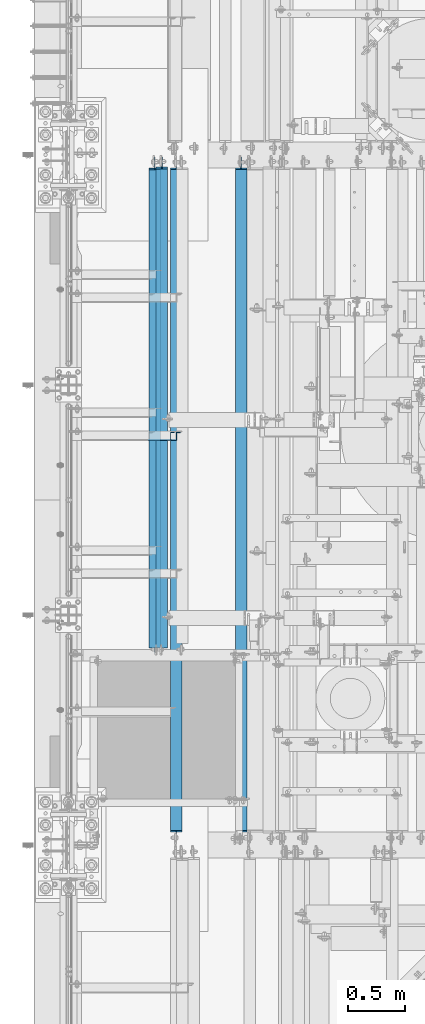
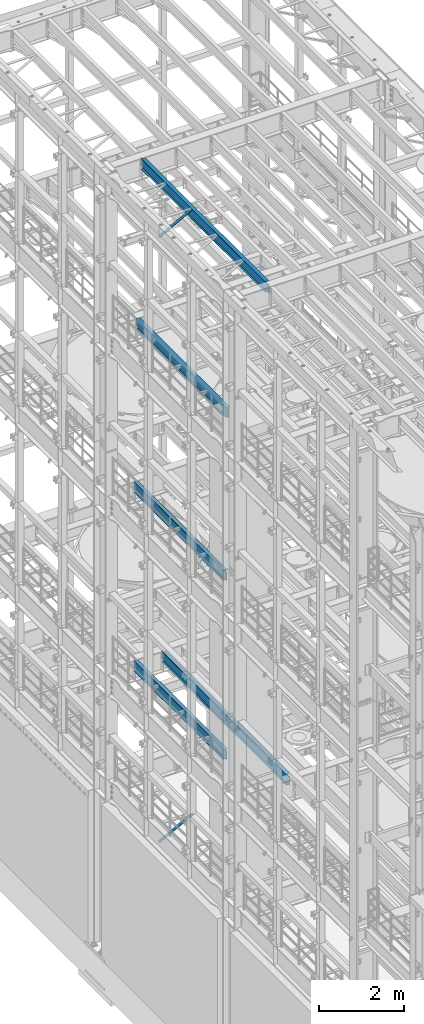
# One storey, part 1023 of 1876: 5 beams, 2 members, 7 elements without a shape of their own.
"""IFC2X3 building model written with IfcOpenShell, lengths in millimetres."""

from ifc_helpers import new_model, si_unit, frame, origin_with_axes, place, context, subcontext, project, spatial, faceted_brep, material, type_object, element, aggregate, save


model = new_model("IFC2X3")

# Units and contexts
model_context = context("Model", 3, precision=1e-05, world=origin_with_axes())
body_context = subcontext(model_context, "Body", "Model", "MODEL_VIEW")
ifc_project = project(units=[si_unit("LENGTHUNIT", "METRE", prefix="MILLI"), si_unit("AREAUNIT", "SQUARE_METRE"), si_unit("VOLUMEUNIT", "CUBIC_METRE"), si_unit("MASSUNIT", "GRAM", prefix="KILO"), si_unit("TIMEUNIT", "SECOND"), si_unit("PLANEANGLEUNIT", "RADIAN"), si_unit("SOLIDANGLEUNIT", "STERADIAN"), si_unit("THERMODYNAMICTEMPERATUREUNIT", "DEGREE_CELSIUS"), si_unit("LUMINOUSINTENSITYUNIT", "LUMEN")], contexts=[model_context])

# Site, building, storey
site_placement = place(None, origin_with_axes())
site = spatial("IfcSite", under=ifc_project, at=site_placement, CompositionType="ELEMENT")
building_placement = place(site_placement, origin_with_axes())
building = spatial("IfcBuilding", under=site, at=building_placement, Name="Undefined", CompositionType="ELEMENT")
storey_placement = place(building_placement, origin_with_axes())
storey = spatial("IfcBuildingStorey", under=building, at=storey_placement, Name="Undefined", CompositionType="ELEMENT", Elevation=0.0)

# Assembly, member
assembly_1_placement = place(storey_placement, origin_with_axes())
assembly_1 = element("IfcElementAssembly", 1, at=assembly_1_placement, inside=storey, AssemblyPlace="NOTDEFINED", PredefinedType="RIGID_FRAME")
ifc_material_1 = material(Name="STEEL/A36")
member_type = type_object("IfcMemberType", Name="L3X3X3/8", PredefinedType="NOTDEFINED")
member_1_placement = place(assembly_1_placement, frame((18.2754879686868, 5133.975, 22001.0692535961), z_axis=(0.0, -1.0, 0.0), x_axis=(0.877448093107104, 0.0, 0.479671600058526)))
member_1 = element("IfcMember", 2, at=member_1_placement, type_object=member_type, material=ifc_material_1, ObjectType="L3X3X3/8", context=body_context, shape_type="Brep", body=[
    faceted_brep([(22.6152978728696, 38.0999999999985, -38.0999999999999), (22.6152978728696, 38.0999999999985, 38.0999999999999), (1025.78606203808, 38.1000000013628, 38.0999999999999), (1025.78606203808, 38.1000000013628, -38.0999999999999), (22.6152978728605, 28.5750000000044, 38.0999999999999), (1025.78606203807, 28.5750000013722, 38.0999999999999), (22.6152978728605, 28.5750000000044, -28.5749999999998), (1025.78606203807, 28.5750000013722, -28.5749999999998), (22.6152978728023, -38.0999999999367, -28.5749999999998), (1025.78606203801, -38.0999999985652, -28.5749999999998), (22.6152978728023, -38.0999999999367, -38.0999999999999), (1025.78606203801, -38.0999999985652, -38.0999999999999)], [[[0, 1, 2, 3]], [[1, 4, 5, 2]], [[4, 6, 7, 5]], [[6, 8, 9, 7]], [[8, 10, 11, 9]], [[10, 0, 3, 11]], [[5, 7, 9, 11, 3, 2]], [[10, 8, 6, 4, 1, 0]]]),
])
aggregate(assembly_1, [member_1])

assembly_2_placement = place(storey_placement, origin_with_axes())
assembly_2 = element("IfcElementAssembly", 3, at=assembly_2_placement, inside=storey, AssemblyPlace="NOTDEFINED", PredefinedType="RIGID_FRAME")
member_2_placement = place(assembly_2_placement, frame((17.6081923269563, 5133.975, 4576.47197854001), z_axis=(0.0, -1.0, 0.0), x_axis=(0.885896503105539, 0.0, 0.463882944055263)))
member_2 = element("IfcMember", 4, at=member_2_placement, type_object=member_type, material=ifc_material_1, ObjectType="L3X3X3/8", context=body_context, shape_type="Brep", body=[
    faceted_brep([(22.4738417769599, 38.1000000000004, -38.0999999999999), (22.4738417769599, 38.1000000000004, 38.0999999999999), (1074.30197854536, 38.1000000002496, 38.0999999999999), (1074.30197854536, 38.1000000002496, -38.0999999999999), (22.4738417769613, 28.5749999999998, 38.0999999999999), (1074.30197854535, 28.5750000002463, 38.0999999999999), (22.4738417769613, 28.5749999999998, -28.5749999999998), (1074.30197854535, 28.5750000002463, -28.5749999999998), (22.4738417769699, -38.100000000004, -28.5749999999998), (1074.30197854533, -38.099999999773, -28.5749999999998), (22.4738417769699, -38.100000000004, -38.0999999999999), (1074.30197854533, -38.099999999773, -38.0999999999999)], [[[0, 1, 2, 3]], [[1, 4, 5, 2]], [[4, 6, 7, 5]], [[6, 8, 9, 7]], [[8, 10, 11, 9]], [[10, 0, 3, 11]], [[5, 7, 9, 11, 3, 2]], [[10, 8, 6, 4, 1, 0]]]),
])
aggregate(assembly_2, [member_2])

# Assembly, beam
assembly_3_placement = place(storey_placement, origin_with_axes())
assembly_3 = element("IfcElementAssembly", 5, at=assembly_3_placement, inside=storey, Name="BEAM", AssemblyPlace="NOTDEFINED", PredefinedType="RIGID_FRAME")
ifc_material_2 = material(Name="STEEL/A992")
beam_type = type_object("IfcBeamType", Name="W12X16", PredefinedType="NOTDEFINED")
beam_1_placement = place(assembly_3_placement, frame((825.5, 3149.6, 17830.8), z_axis=(0.0, 0.0, 1.0), x_axis=(0.0, 1.0, 0.0)))
beam_1 = element("IfcBeam", 6, at=beam_1_placement, type_object=beam_type, material=ifc_material_2, Name="BEAM", ObjectType="W12X16", context=body_context, shape_type="Brep", body=[
    faceted_brep([(66.6750000000002, -3.17499999999995, -127.0), (66.6750000000002, 3.17499999999995, -127.0), (142.875000190735, 3.17499999999995, -127.0), (142.875000190735, -3.17499999999995, -127.0), (147.73507970878, 3.17499999999995, -127.966729922588), (147.73507970878, -3.17499999999995, -127.966729922588), (151.855256176934, 3.17499999999995, -130.719743823065), (151.855256176934, -3.17499999999995, -130.719743823065), (154.608270077412, 3.17499999999995, -134.839920291219), (154.608270077412, -3.17499999999995, -134.839920291219), (155.575, -3.17499999999995, -139.699999809265), (155.575, 3.17499999999995, -139.699999809265), (155.575, 3.17499999999995, -146.049999999999), (155.575, 50.8, -146.049999999999), (155.575, 50.8, -152.400000000001), (155.575, -50.8, -152.400000000001), (155.575, -50.8, -146.049999999999), (155.575, -3.17499999999995, -146.049999999999), (142.874999999999, 50.8, 146.049999999999), (4344.19375, 50.8, 146.049999999999), (4344.19375, 3.17499999999995, 146.049999999999), (142.875, 3.17499999999995, 146.049999999999), (114.3, 3.17499999999995, 146.049999999999), (114.3, 50.8, 146.049999999999), (101.600000190735, -3.17499999999995, 127.0), (101.600000190735, 3.17499999999995, 127.0), (66.6750000000002, 3.17499999999995, 127.0), (66.6750000000002, -3.17499999999995, 127.0), (106.46007970878, -3.17499999999995, 127.966729922588), (106.46007970878, 3.17499999999995, 127.966729922588), (110.580256176934, -3.17499999999995, 130.719743823065), (110.580256176934, 3.17499999999995, 130.719743823065), (113.333270077412, -3.17499999999995, 134.839920291219), (113.333270077412, 3.17499999999995, 134.839920291219), (114.3, -3.17499999999995, 139.699999809265), (114.3, 3.17499999999995, 139.699999809265), (4344.19375, -50.8, 152.400000000001), (4344.19375, 50.8, 152.400000000001), (114.3, 50.8, 152.400000000001), (114.3, -50.8, 152.400000000001), (4344.19375, -50.8, 146.049999999999), (114.3, -50.8, 146.049999999999), (4344.19375, -3.17499999999995, 146.049999999999), (114.3, -3.17499999999995, 146.049999999999), (4344.19375, -3.17499999999995, 120.64999980927), (4344.19375, 3.17499999999995, 120.64999980927), (4345.16047992259, -3.17499999999995, 115.789920291223), (4345.16047992259, 3.17499999999995, 115.789920291223), (4347.91349382307, -3.17499999999995, 111.669743823069), (4347.91349382307, 3.17499999999995, 111.669743823069), (4352.03367029122, -3.17499999999995, 108.916729922592), (4352.03367029122, 3.17499999999995, 108.916729922592), (4356.89374980927, -3.17499999999995, 107.950000000004), (4356.89374980927, 3.17499999999995, 107.950000000004), (4450.55625, -3.17499999999995, 107.950000000004), (4450.55625, 3.17499999999995, 107.950000000004), (4450.55625, -3.17499999999995, -126.999999999996), (4450.55625, 3.17499999999995, -126.999999999996), (4374.35624980927, -3.17499999999995, -126.999999999996), (4374.35624980927, 3.17499999999995, -126.999999999996), (4369.49617029122, -3.17499999999995, -127.966729922584), (4369.49617029122, 3.17499999999995, -127.966729922584), (4365.37599382307, -3.17499999999995, -130.719743823061), (4365.37599382307, 3.17499999999995, -130.719743823061), (4362.62297992259, -3.17499999999995, -134.839920291215), (4362.62297992259, 3.17499999999995, -134.839920291215), (4361.65625, -3.17499999999995, -139.699999809261), (4361.65625, 3.17499999999995, -139.699999809261), (4361.65625, -3.17499999999995, -146.049999999999), (4361.65625, -50.8, -146.049999999999), (4361.65625, -50.8, -152.400000000001), (4361.65625, 50.8, -152.400000000001), (4361.65625, 50.8, -146.049999999999), (4361.65625, 3.17499999999995, -146.049999999999)], [[[0, 1, 2, 3]], [[3, 2, 4, 5]], [[5, 4, 6, 7]], [[7, 6, 8, 9]], [[10, 11, 12, 13, 14, 15, 16, 17]], [[9, 8, 11, 10]], [[18, 19, 20, 21, 22, 23]], [[24, 25, 26, 27]], [[28, 29, 25, 24]], [[30, 31, 29, 28]], [[32, 33, 31, 30]], [[34, 35, 33, 32]], [[36, 37, 38, 39]], [[40, 36, 39, 41]], [[42, 40, 41, 43]], [[39, 38, 23, 22, 35, 34, 43, 41]], [[37, 19, 18, 23, 38]], [[36, 40, 42, 44, 45, 20, 19, 37]], [[46, 47, 45, 44]], [[48, 49, 47, 46]], [[50, 51, 49, 48]], [[52, 53, 51, 50]], [[54, 55, 53, 52]], [[55, 54, 56, 57]], [[56, 58, 59, 57]], [[60, 61, 59, 58]], [[62, 63, 61, 60]], [[64, 65, 63, 62]], [[66, 67, 65, 64]], [[68, 69, 70, 71, 72, 73, 67, 66]], [[69, 68, 17, 16]], [[70, 69, 16, 15]], [[71, 70, 15, 14]], [[72, 71, 14, 13]], [[73, 72, 13, 12]], [[6, 4, 2, 1, 26, 25, 29, 31, 33, 35, 22, 21, 20, 45, 47, 49, 51, 53, 55, 57, 59, 61, 63, 65, 67, 73, 12, 11, 8]], [[27, 26, 1, 0]], [[68, 66, 64, 62, 60, 58, 56, 54, 52, 50, 48, 46, 44, 42, 43, 34, 32, 30, 28, 24, 27, 0, 3, 5, 7, 9, 10, 17]]]),
])
aggregate(assembly_3, [beam_1])

assembly_4_placement = place(storey_placement, origin_with_axes())
assembly_4 = element("IfcElementAssembly", 7, at=assembly_4_placement, inside=storey, Name="BEAM", AssemblyPlace="NOTDEFINED", PredefinedType="RIGID_FRAME")
beam_2_placement = place(assembly_4_placement, frame((762.0, 3149.6, 13157.2), z_axis=(0.0, 0.0, 1.0), x_axis=(0.0, 1.0, 0.0)))
beam_2 = element("IfcBeam", 8, at=beam_2_placement, type_object=beam_type, material=ifc_material_2, Name="BEAM", ObjectType="W12X16", context=body_context, shape_type="Brep", body=[
    faceted_brep([(66.6750000000002, -3.17499999999995, -127.0), (66.6750000000002, 3.17499999999995, -127.0), (142.875000190735, 3.17499999999995, -127.0), (142.875000190735, -3.17499999999995, -127.0), (147.73507970878, 3.17499999999995, -127.966729922588), (147.73507970878, -3.17499999999995, -127.966729922588), (151.855256176934, 3.17499999999995, -130.719743823065), (151.855256176934, -3.17499999999995, -130.719743823065), (154.608270077412, 3.17499999999995, -134.839920291219), (154.608270077412, -3.17499999999995, -134.839920291219), (155.575, -3.17499999999995, -139.699999809265), (155.575, 3.17499999999995, -139.699999809265), (155.575, 3.17499999999995, -146.049999999999), (155.575, 50.8, -146.049999999999), (155.575, 50.8, -152.400000000001), (155.575, -50.8, -152.400000000001), (155.575, -50.8, -146.049999999999), (155.575, -3.17499999999995, -146.049999999999), (4336.25625, 50.8, 146.049999999999), (4336.25625, 3.17499999999995, 146.049999999999), (114.3, 3.17499999999995, 146.049999999999), (114.3, 50.8, 146.049999999999), (101.600000190735, -3.17499999999995, 127.0), (101.600000190735, 3.17499999999995, 127.0), (66.6750000000002, 3.17499999999995, 127.0), (66.6750000000002, -3.17499999999995, 127.0), (106.46007970878, -3.17499999999995, 127.966729922588), (106.46007970878, 3.17499999999995, 127.966729922588), (110.580256176934, -3.17499999999995, 130.719743823065), (110.580256176934, 3.17499999999995, 130.719743823065), (113.333270077412, -3.17499999999995, 134.839920291219), (113.333270077412, 3.17499999999995, 134.839920291219), (114.3, -3.17499999999995, 139.699999809265), (114.3, 3.17499999999995, 139.699999809265), (4336.25625, -50.8, 152.4), (4336.25625, 50.8, 152.4), (114.3, 50.8, 152.400000000001), (114.3, -50.8, 152.400000000001), (4336.25625, -50.8, 146.049999999999), (114.3, -50.8, 146.049999999999), (4336.25625, -3.17499999999995, 146.049999999999), (114.3, -3.17499999999995, 146.049999999999), (4336.25625, -3.17499999999995, 126.999999809264), (4336.25625, 3.17499999999995, 126.999999809264), (4337.22297992259, -3.17499999999995, 122.139920291218), (4337.22297992259, 3.17499999999995, 122.139920291218), (4339.97599382307, -3.17499999999995, 118.019743823064), (4339.97599382307, 3.17499999999995, 118.019743823064), (4344.09617029122, -3.17499999999995, 115.266729922587), (4344.09617029122, 3.17499999999995, 115.266729922587), (4348.95624980926, -3.17499999999995, 114.299999999999), (4348.95624980926, 3.17499999999995, 114.299999999999), (4450.55625, -3.17499999999995, 114.299999999999), (4450.55625, 3.17499999999995, 114.299999999999), (4450.55625, -3.17499999999995, -126.999999999996), (4450.55625, 3.17499999999995, -126.999999999996), (4361.65624980926, -3.17499999999995, -127.0), (4361.65624980926, 3.17499999999995, -127.0), (4356.79617029122, -3.17499999999995, -127.966729922588), (4356.79617029122, 3.17499999999995, -127.966729922588), (4352.67599382307, -3.17499999999995, -130.719743823065), (4352.67599382307, 3.17499999999995, -130.719743823065), (4349.92297992259, -3.17499999999995, -134.839920291219), (4349.92297992259, 3.17499999999995, -134.839920291219), (4348.95625, -3.17499999999995, -139.699999809265), (4348.95625, 3.17499999999995, -139.699999809265), (4348.95625, -3.17499999999995, -146.049999999999), (4348.95625, -50.8, -146.049999999999), (4348.95625, -50.8, -152.4), (4348.95625, 50.8, -152.4), (4348.95625, 50.8, -146.049999999999), (4348.95625, 3.17499999999995, -146.049999999999)], [[[0, 1, 2, 3]], [[3, 2, 4, 5]], [[5, 4, 6, 7]], [[7, 6, 8, 9]], [[10, 11, 12, 13, 14, 15, 16, 17]], [[9, 8, 11, 10]], [[18, 19, 20, 21]], [[22, 23, 24, 25]], [[26, 27, 23, 22]], [[28, 29, 27, 26]], [[30, 31, 29, 28]], [[32, 33, 31, 30]], [[34, 35, 36, 37]], [[38, 34, 37, 39]], [[40, 38, 39, 41]], [[37, 36, 21, 20, 33, 32, 41, 39]], [[35, 18, 21, 36]], [[34, 38, 40, 42, 43, 19, 18, 35]], [[44, 45, 43, 42]], [[46, 47, 45, 44]], [[48, 49, 47, 46]], [[50, 51, 49, 48]], [[52, 53, 51, 50]], [[53, 52, 54, 55]], [[54, 56, 57, 55]], [[58, 59, 57, 56]], [[60, 61, 59, 58]], [[62, 63, 61, 60]], [[64, 65, 63, 62]], [[66, 67, 68, 69, 70, 71, 65, 64]], [[67, 66, 17, 16]], [[68, 67, 16, 15]], [[69, 68, 15, 14]], [[70, 69, 14, 13]], [[71, 70, 13, 12]], [[6, 4, 2, 1, 24, 23, 27, 29, 31, 33, 20, 19, 43, 45, 47, 49, 51, 53, 55, 57, 59, 61, 63, 65, 71, 12, 11, 8]], [[25, 24, 1, 0]], [[66, 64, 62, 60, 58, 56, 54, 52, 50, 48, 46, 44, 42, 40, 41, 32, 30, 28, 26, 22, 25, 0, 3, 5, 7, 9, 10, 17]]]),
])
aggregate(assembly_4, [beam_2])

assembly_5_placement = place(storey_placement, origin_with_axes())
assembly_5 = element("IfcElementAssembly", 9, at=assembly_5_placement, inside=storey, Name="BEAM", AssemblyPlace="NOTDEFINED", PredefinedType="RIGID_FRAME")
beam_3_placement = place(assembly_5_placement, frame((1524.00012207031, 1524.0, 8001.0), z_axis=(0.0, 0.0, 1.0), x_axis=(0.0, 1.0, 0.0)))
beam_3 = element("IfcBeam", 10, at=beam_3_placement, type_object=beam_type, material=ifc_material_2, Name="BEAM", ObjectType="W12X16", context=body_context, shape_type="Brep", body=[
    faceted_brep([(5980.90625, -3.17499999999995, -146.05), (5980.90625, -50.8, -146.05), (5980.90625, -50.8, -152.4), (5980.90625, 50.8, -152.4), (5980.90625, 50.8, -146.05), (5980.90625, 3.17499999999995, -146.05), (5980.90625, 3.17499999999995, -139.699999809266), (5980.90625, -3.17499999999995, -139.699999809266), (5981.87297992259, 3.17499999999995, -134.839920291221), (5981.87297992259, -3.17499999999995, -134.839920291221), (5984.62599382307, 3.17499999999995, -130.719743823067), (5984.62599382307, -3.17499999999995, -130.719743823067), (5988.74617029122, 3.17499999999995, -127.966729922588), (5988.74617029122, -3.17499999999995, -127.966729922588), (5993.60624980927, 3.17499999999995, -127.000000000001), (5993.60624980927, -3.17499999999995, -127.000000000001), (6076.15625, -3.17499999999995, -126.999999999996), (6076.15625, 3.17499999999995, -126.999999999996), (127.79375, 3.17500000000018, 146.05), (127.79375, 50.8000000000002, 146.05), (5968.20625, 50.8, 146.05), (5968.20625, 3.17499999999995, 146.05), (115.09375, -3.17500000000018, -139.699999809266), (115.09375, 3.17500000000018, -139.699999809266), (115.09375, 3.17500000000018, -146.05), (115.09375, 50.8000000000002, -146.05), (115.09375, 50.8000000000002, -152.4), (115.09375, -50.8000000000002, -152.4), (115.09375, -50.8000000000002, -146.05), (115.09375, -3.17500000000018, -146.05), (114.127020077412, -3.17500000000018, -134.839920291221), (114.127020077412, 3.17500000000018, -134.839920291221), (111.374006176934, -3.17500000000018, -130.719743823067), (111.374006176934, 3.17500000000018, -130.719743823067), (107.25382970878, -3.17500000000018, -127.966729922588), (107.25382970878, 3.17500000000018, -127.966729922588), (102.393750190735, -3.17500000000018, -127.000000000001), (102.393750190735, 3.17500000000018, -127.000000000001), (19.84375, -3.17499999999995, -126.999999999996), (19.84375, 3.17499999999995, -126.999999999996), (19.84375, -3.17500000000018, 114.299999999999), (19.84375, 3.17500000000018, 114.299999999999), (115.093750190735, -3.17500000000018, 114.299999999999), (115.093750190735, 3.17500000000018, 114.299999999999), (119.95382970878, -3.17500000000018, 115.266729922587), (119.95382970878, 3.17500000000018, 115.266729922587), (124.074006176934, -3.17500000000018, 118.019743823065), (124.074006176934, 3.17500000000018, 118.019743823065), (126.827020077412, -3.17500000000018, 122.139920291219), (126.827020077412, 3.17500000000018, 122.139920291219), (127.79375, -3.17500000000018, 126.999999809264), (127.79375, 3.17500000000018, 126.999999809264), (127.79375, -50.8000000000002, 152.4), (127.79375, 50.8000000000002, 152.4), (127.79375, -3.17500000000018, 146.05), (127.79375, -50.8000000000002, 146.05), (5968.20625, -3.17499999999995, 146.05), (5968.20625, -50.8, 146.05), (5968.20625, -50.8, 152.4), (5968.20625, 50.8, 152.4), (5968.20625, -3.17499999999995, 126.999999809264), (5968.20625, 3.17499999999995, 126.999999809264), (5969.17297992259, -3.17499999999995, 122.139920291219), (5969.17297992259, 3.17499999999995, 122.139920291219), (5971.92599382307, -3.17499999999995, 118.019743823065), (5971.92599382307, 3.17499999999995, 118.019743823065), (5976.04617029122, -3.17499999999995, 115.266729922587), (5976.04617029122, 3.17499999999995, 115.266729922587), (5980.90624980927, -3.17499999999995, 114.299999999999), (5980.90624980927, 3.17499999999995, 114.299999999999), (6076.15625, -3.17499999999995, 114.299999999999), (6076.15625, 3.17499999999995, 114.299999999999)], [[[0, 1, 2, 3, 4, 5, 6, 7]], [[7, 6, 8, 9]], [[9, 8, 10, 11]], [[11, 10, 12, 13]], [[13, 12, 14, 15]], [[16, 15, 14, 17]], [[18, 19, 20, 21]], [[22, 23, 24, 25, 26, 27, 28, 29]], [[30, 31, 23, 22]], [[32, 33, 31, 30]], [[34, 35, 33, 32]], [[36, 37, 35, 34]], [[38, 39, 37, 36]], [[40, 41, 39, 38]], [[42, 43, 41, 40]], [[44, 45, 43, 42]], [[46, 47, 45, 44]], [[48, 49, 47, 46]], [[50, 51, 49, 48]], [[52, 53, 19, 18, 51, 50, 54, 55]], [[55, 54, 56, 57]], [[52, 55, 57, 58]], [[53, 52, 58, 59]], [[19, 53, 59, 20]], [[58, 57, 56, 60, 61, 21, 20, 59]], [[62, 63, 61, 60]], [[64, 65, 63, 62]], [[66, 67, 65, 64]], [[68, 69, 67, 66]], [[70, 71, 69, 68]], [[71, 70, 16, 17]], [[12, 10, 8, 6, 5, 24, 23, 31, 33, 35, 37, 39, 41, 43, 45, 47, 49, 51, 18, 21, 61, 63, 65, 67, 69, 71, 17, 14]], [[25, 24, 5, 4]], [[26, 25, 4, 3]], [[27, 26, 3, 2]], [[28, 27, 2, 1]], [[29, 28, 1, 0]], [[70, 68, 66, 64, 62, 60, 56, 54, 50, 48, 46, 44, 42, 40, 38, 36, 34, 32, 30, 22, 29, 0, 7, 9, 11, 13, 15, 16]]]),
])
aggregate(assembly_5, [beam_3])

assembly_6_placement = place(storey_placement, origin_with_axes())
assembly_6 = element("IfcElementAssembly", 11, at=assembly_6_placement, inside=storey, Name="BEAM", AssemblyPlace="NOTDEFINED", PredefinedType="RIGID_FRAME")
beam_4_placement = place(assembly_6_placement, frame((762.0, 3225.8, 8001.0), z_axis=(0.0, 0.0, 1.0), x_axis=(0.0, 1.0, 0.0)))
beam_4 = element("IfcBeam", 12, at=beam_4_placement, type_object=beam_type, material=ifc_material_2, Name="BEAM", ObjectType="W12X16", context=body_context, shape_type="Brep", body=[
    faceted_brep([(-9.52500000000009, -3.17499999999995, -127.000000000001), (-9.52500000000009, 3.17499999999995, -127.000000000001), (66.6750000000002, 3.17499999999995, -127.0), (66.6750000000002, -3.17499999999995, -127.0), (71.5350797087794, 3.17499999999995, -127.966729922588), (71.5350797087794, -3.17499999999995, -127.966729922588), (75.6552561769331, 3.17499999999995, -130.719743823067), (75.6552561769331, -3.17499999999995, -130.719743823067), (78.4082700774111, 3.17499999999995, -134.839920291221), (78.4082700774111, -3.17499999999995, -134.839920291221), (79.3749999999991, -3.17499999999995, -139.699999809266), (79.3749999999991, 3.17499999999995, -139.699999809266), (79.3749999999991, 3.17499999999995, -146.05), (79.3749999999991, 50.8, -146.05), (79.3749999999991, 50.8, -152.4), (79.3749999999991, -50.8, -152.4), (79.3749999999991, -50.8, -146.05), (79.3749999999991, -3.17499999999995, -146.05), (4266.40625, 50.8, 146.05), (4266.40625, 3.17499999999995, 146.05), (38.0999999999995, 3.17499999999995, 146.05), (38.0999999999995, 50.8, 146.05), (25.4000001907339, -3.17499999999995, 126.999999999999), (25.4000001907339, 3.17499999999995, 126.999999999999), (-9.52500000000009, 3.17499999999995, 126.999999999999), (-9.52500000000009, -3.17499999999995, 126.999999999999), (30.2600797087794, -3.17499999999995, 127.966729922587), (30.2600797087794, 3.17499999999995, 127.966729922587), (34.380256176933, -3.17499999999995, 130.719743823065), (34.380256176933, 3.17499999999995, 130.719743823065), (37.133270077411, -3.17499999999995, 134.839920291219), (37.133270077411, 3.17499999999995, 134.839920291219), (38.099999999999, -3.17499999999995, 139.699999809264), (38.099999999999, 3.17499999999995, 139.699999809264), (4266.40625, -50.8, 152.4), (4266.40625, 50.8, 152.4), (38.0999999999995, 50.8, 152.4), (38.0999999999995, -50.8, 152.4), (4266.40625, -50.8, 146.05), (38.0999999999995, -50.8, 146.05), (4266.40625, -3.17499999999995, 146.05), (38.0999999999995, -3.17499999999995, 146.05), (4266.40625, -3.17499999999995, 126.999999809264), (4266.40625, 3.17499999999995, 126.999999809264), (4267.37297992259, -3.17499999999995, 122.139920291219), (4267.37297992259, 3.17499999999995, 122.139920291219), (4270.12599382307, -3.17499999999995, 118.019743823065), (4270.12599382307, 3.17499999999995, 118.019743823065), (4274.24617029122, -3.17499999999995, 115.266729922587), (4274.24617029122, 3.17499999999995, 115.266729922587), (4279.10624980927, -3.17499999999995, 114.299999999999), (4279.10624980927, 3.17499999999995, 114.299999999999), (4374.35625, -3.17499999999995, 114.299999999999), (4374.35625, 3.17499999999995, 114.299999999999), (4374.35624980927, -3.17499999999995, -126.999999999996), (4374.35624980927, 3.17499999999995, -126.999999999996), (4291.80624980927, -3.17499999999995, -127.000000000001), (4291.80624980927, 3.17499999999995, -127.000000000001), (4286.94617029122, -3.17499999999995, -127.966729922588), (4286.94617029122, 3.17499999999995, -127.966729922588), (4282.82599382307, -3.17499999999995, -130.719743823067), (4282.82599382307, 3.17499999999995, -130.719743823067), (4280.07297992259, -3.17499999999995, -134.839920291221), (4280.07297992259, 3.17499999999995, -134.839920291221), (4279.10625, -3.17499999999995, -139.699999809266), (4279.10625, 3.17499999999995, -139.699999809266), (4279.10625, -3.17499999999995, -146.05), (4279.10625, -50.8, -146.05), (4279.10625, -50.8, -152.4), (4279.10625, 50.8, -152.4), (4279.10625, 50.8, -146.05), (4279.10625, 3.17499999999995, -146.05)], [[[0, 1, 2, 3]], [[3, 2, 4, 5]], [[5, 4, 6, 7]], [[7, 6, 8, 9]], [[10, 11, 12, 13, 14, 15, 16, 17]], [[9, 8, 11, 10]], [[18, 19, 20, 21]], [[22, 23, 24, 25]], [[26, 27, 23, 22]], [[28, 29, 27, 26]], [[30, 31, 29, 28]], [[32, 33, 31, 30]], [[34, 35, 36, 37]], [[38, 34, 37, 39]], [[40, 38, 39, 41]], [[37, 36, 21, 20, 33, 32, 41, 39]], [[35, 18, 21, 36]], [[34, 38, 40, 42, 43, 19, 18, 35]], [[44, 45, 43, 42]], [[46, 47, 45, 44]], [[48, 49, 47, 46]], [[50, 51, 49, 48]], [[52, 53, 51, 50]], [[53, 52, 54, 55]], [[54, 56, 57, 55]], [[58, 59, 57, 56]], [[60, 61, 59, 58]], [[62, 63, 61, 60]], [[64, 65, 63, 62]], [[66, 67, 68, 69, 70, 71, 65, 64]], [[67, 66, 17, 16]], [[68, 67, 16, 15]], [[69, 68, 15, 14]], [[70, 69, 14, 13]], [[71, 70, 13, 12]], [[6, 4, 2, 1, 24, 23, 27, 29, 31, 33, 20, 19, 43, 45, 47, 49, 51, 53, 55, 57, 59, 61, 63, 65, 71, 12, 11, 8]], [[25, 24, 1, 0]], [[66, 64, 62, 60, 58, 56, 54, 52, 50, 48, 46, 44, 42, 40, 41, 32, 30, 28, 26, 22, 25, 0, 3, 5, 7, 9, 10, 17]]]),
])
aggregate(assembly_6, [beam_4])

assembly_7_placement = place(storey_placement, origin_with_axes())
assembly_7 = element("IfcElementAssembly", 13, at=assembly_7_placement, inside=storey, Name="BEAM", AssemblyPlace="NOTDEFINED", PredefinedType="RIGID_FRAME")
beam_5_placement = place(assembly_7_placement, frame((952.5, 1524.0, 22402.8), z_axis=(0.0, 0.0, 1.0), x_axis=(0.0, 1.0, 0.0)))
beam_5 = element("IfcBeam", 14, at=beam_5_placement, type_object=beam_type, material=ifc_material_2, Name="BEAM", ObjectType="W12X16", context=body_context, shape_type="Brep", body=[
    faceted_brep([(19.84375, -3.17499999999995, -126.999999999996), (19.84375, 3.17499999999995, -126.999999999996), (102.393750190735, 3.17500000000018, -127.000000000001), (102.393750190735, -3.17500000000018, -127.000000000001), (107.25382970878, 3.17500000000018, -127.966729922588), (107.25382970878, -3.17500000000018, -127.966729922588), (111.374006176934, 3.17500000000018, -130.719743823067), (111.374006176934, -3.17500000000018, -130.719743823067), (114.127020077412, 3.17500000000018, -134.839920291221), (114.127020077412, -3.17500000000018, -134.839920291221), (115.09375, -3.17500000000018, -139.699999809266), (115.09375, 3.17500000000018, -139.699999809266), (115.09375, 3.17500000000018, -146.05), (115.09375, 50.8000000000002, -146.05), (115.09375, 50.8000000000002, -152.4), (115.09375, -50.8000000000002, -152.4), (115.09375, -50.8000000000002, -146.05), (115.09375, -3.17500000000018, -146.05), (127.79375, 3.17500000000018, 146.05), (127.79375, 50.8000000000002, 146.05), (5968.20625, 50.8, 146.05), (5968.20625, 3.17499999999995, 146.05), (115.093750190735, -3.17500000000018, 114.299999999999), (115.093750190735, 3.17500000000018, 114.299999999999), (19.84375, 3.17500000000018, 114.299999999999), (19.84375, -3.17500000000018, 114.299999999999), (119.95382970878, -3.17500000000018, 115.266729922587), (119.95382970878, 3.17500000000018, 115.266729922587), (124.074006176934, -3.17500000000018, 118.019743823065), (124.074006176934, 3.17500000000018, 118.019743823065), (126.827020077412, -3.17500000000018, 122.139920291219), (126.827020077412, 3.17500000000018, 122.139920291219), (127.79375, -3.17500000000018, 126.999999809264), (127.79375, 3.17500000000018, 126.999999809264), (127.79375, 50.8000000000002, 152.4), (127.79375, -50.8000000000002, 152.4), (5968.20625, -50.8, 152.4), (5968.20625, 50.8, 152.4), (127.79375, -50.8000000000002, 146.05), (5968.20625, -50.8, 146.05), (127.79375, -3.17500000000018, 146.05), (5968.20625, -3.17499999999995, 146.05), (5968.20625, -3.17499999999995, 126.999999809264), (5968.20625, 3.17499999999995, 126.999999809264), (5969.17297992259, -3.17499999999995, 122.139920291219), (5969.17297992259, 3.17499999999995, 122.139920291219), (5971.92599382307, -3.17499999999995, 118.019743823065), (5971.92599382307, 3.17499999999995, 118.019743823065), (5976.04617029122, -3.17499999999995, 115.266729922587), (5976.04617029122, 3.17499999999995, 115.266729922587), (5980.90624980927, -3.17499999999995, 114.299999999999), (5980.90624980927, 3.17499999999995, 114.299999999999), (6076.15625, -3.17499999999995, 114.299999999999), (6076.15625, 3.17499999999995, 114.299999999999), (6076.15625, -3.17499999999995, -126.999999999996), (6076.15625, 3.17499999999995, -126.999999999996), (5993.60624980927, -3.17499999999995, -127.000000000001), (5993.60624980927, 3.17499999999995, -127.000000000001), (5988.74617029122, -3.17499999999995, -127.966729922588), (5988.74617029122, 3.17499999999995, -127.966729922588), (5984.62599382307, -3.17499999999995, -130.719743823067), (5984.62599382307, 3.17499999999995, -130.719743823067), (5981.87297992259, -3.17499999999995, -134.839920291221), (5981.87297992259, 3.17499999999995, -134.839920291221), (5980.90625, -3.17499999999995, -139.699999809266), (5980.90625, 3.17499999999995, -139.699999809266), (5980.90625, -3.17499999999995, -146.05), (5980.90625, -50.8, -146.05), (5980.90625, -50.8, -152.4), (5980.90625, 50.8, -152.4), (5980.90625, 50.8, -146.05), (5980.90625, 3.17499999999995, -146.05)], [[[0, 1, 2, 3]], [[3, 2, 4, 5]], [[5, 4, 6, 7]], [[7, 6, 8, 9]], [[10, 11, 12, 13, 14, 15, 16, 17]], [[9, 8, 11, 10]], [[18, 19, 20, 21]], [[22, 23, 24, 25]], [[26, 27, 23, 22]], [[28, 29, 27, 26]], [[30, 31, 29, 28]], [[32, 33, 31, 30]], [[34, 35, 36, 37]], [[35, 38, 39, 36]], [[38, 40, 41, 39]], [[35, 34, 19, 18, 33, 32, 40, 38]], [[19, 34, 37, 20]], [[36, 39, 41, 42, 43, 21, 20, 37]], [[44, 45, 43, 42]], [[46, 47, 45, 44]], [[48, 49, 47, 46]], [[50, 51, 49, 48]], [[52, 53, 51, 50]], [[53, 52, 54, 55]], [[54, 56, 57, 55]], [[58, 59, 57, 56]], [[60, 61, 59, 58]], [[62, 63, 61, 60]], [[64, 65, 63, 62]], [[66, 67, 68, 69, 70, 71, 65, 64]], [[17, 16, 67, 66]], [[16, 15, 68, 67]], [[15, 14, 69, 68]], [[14, 13, 70, 69]], [[13, 12, 71, 70]], [[59, 61, 63, 65, 71, 12, 11, 8, 6, 4, 2, 1, 24, 23, 27, 29, 31, 33, 18, 21, 43, 45, 47, 49, 51, 53, 55, 57]], [[25, 24, 1, 0]], [[52, 50, 48, 46, 44, 42, 41, 40, 32, 30, 28, 26, 22, 25, 0, 3, 5, 7, 9, 10, 17, 66, 64, 62, 60, 58, 56, 54]]]),
])
aggregate(assembly_7, [beam_5])

save(model, "model.ifc")
